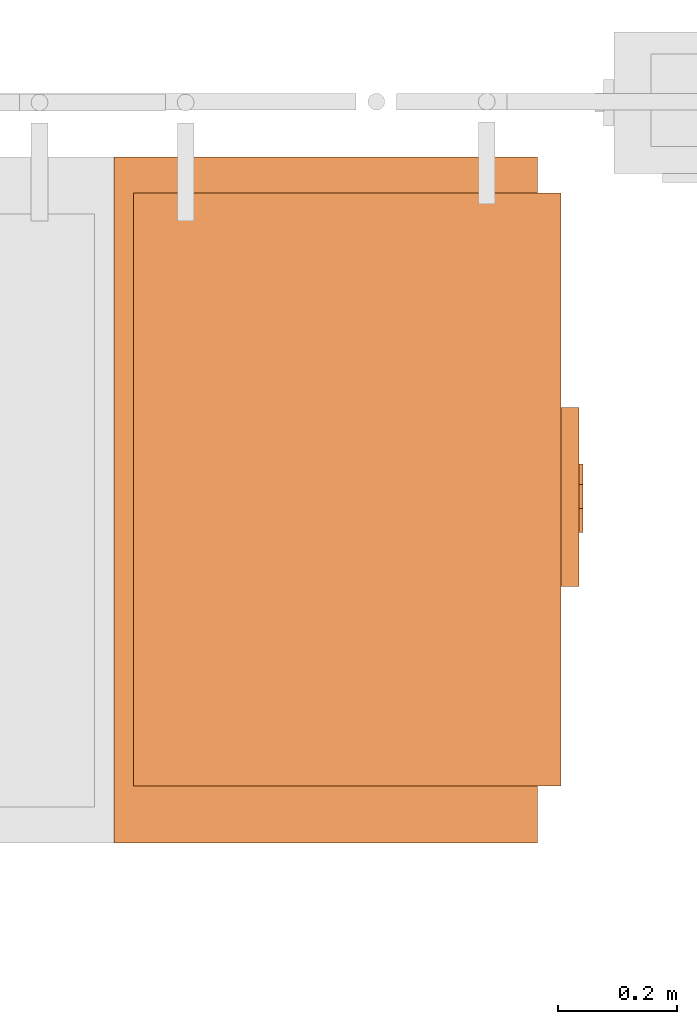
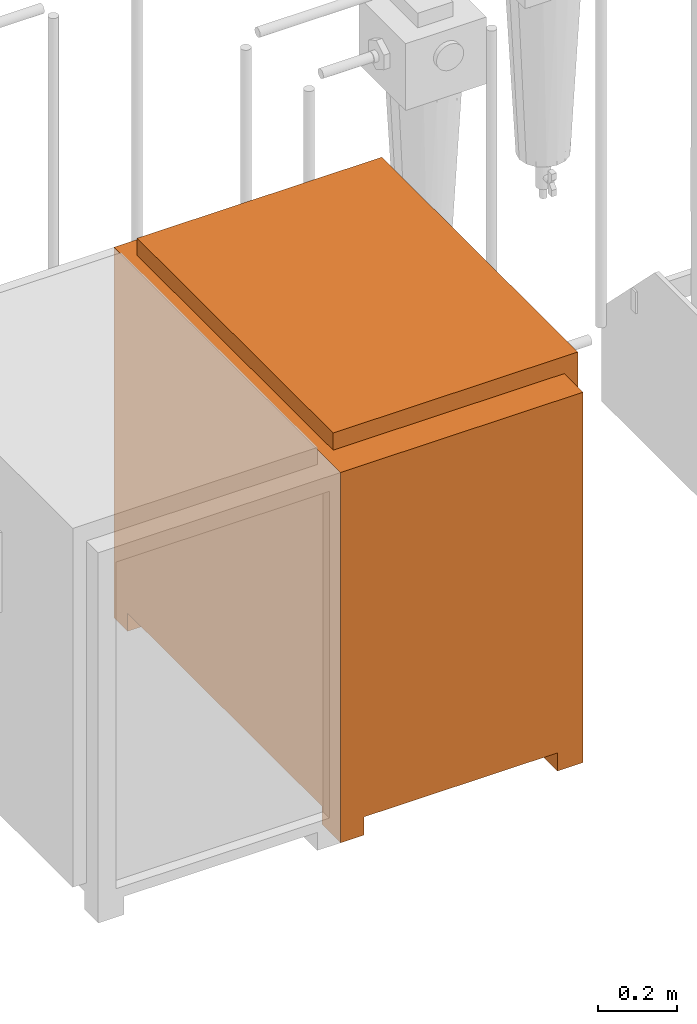
# One storey, part 329 of 331: 1 proxy.
"""IFC2X3 building model written with IfcOpenShell, lengths in millimetres."""

from ifc_helpers import new_model, entity, si_unit, converted_unit, derived_unit, direction, frame, origin, place, context, subcontext, project, spatial, faceted_brep, source, transform, mapped, material, material_list, type_object, type_shapes, element, save


model = new_model("IFC2X3")

# Units and contexts
model_context = context("Model", 3, precision=0.01, world=origin(), true_north=direction((6.12303176911189e-17, 1.0)))
body_context = subcontext(model_context, "Body", "Model", "MODEL_VIEW")
ifc_project = project(units=[si_unit("LENGTHUNIT", "METRE", prefix="MILLI"), si_unit("AREAUNIT", "SQUARE_METRE"), si_unit("VOLUMEUNIT", "CUBIC_METRE"), converted_unit("PLANEANGLEUNIT", "DEGREE", entity("IfcRatioMeasure", 0.0174532925199433), si_unit("PLANEANGLEUNIT", "RADIAN"), dimensions=[0, 0, 0, 0, 0, 0, 0]), si_unit("MASSUNIT", "GRAM", prefix="KILO"), derived_unit("MASSDENSITYUNIT", [(si_unit("MASSUNIT", "GRAM", prefix="KILO"), 1), (si_unit("LENGTHUNIT", "METRE"), -3)]), derived_unit("MOMENTOFINERTIAUNIT", [(si_unit("LENGTHUNIT", "METRE"), 4)]), si_unit("TIMEUNIT", "SECOND"), si_unit("FREQUENCYUNIT", "HERTZ"), si_unit("THERMODYNAMICTEMPERATUREUNIT", "DEGREE_CELSIUS"), derived_unit("THERMALTRANSMITTANCEUNIT", [(si_unit("MASSUNIT", "GRAM", prefix="KILO"), 1), (si_unit("THERMODYNAMICTEMPERATUREUNIT", "KELVIN"), -1), (si_unit("TIMEUNIT", "SECOND"), -3)]), derived_unit("VOLUMETRICFLOWRATEUNIT", [(si_unit("LENGTHUNIT", "METRE"), 3), (si_unit("TIMEUNIT", "SECOND"), -1)]), derived_unit("MASSFLOWRATEUNIT", [(si_unit("MASSUNIT", "GRAM", prefix="KILO"), 1), (si_unit("TIMEUNIT", "SECOND"), -1)]), derived_unit("ROTATIONALFREQUENCYUNIT", [(si_unit("TIMEUNIT", "SECOND"), -1)]), si_unit("ELECTRICCURRENTUNIT", "AMPERE"), si_unit("ELECTRICVOLTAGEUNIT", "VOLT"), si_unit("POWERUNIT", "WATT"), si_unit("FORCEUNIT", "NEWTON", prefix="KILO"), si_unit("ILLUMINANCEUNIT", "LUX"), si_unit("LUMINOUSFLUXUNIT", "LUMEN"), si_unit("LUMINOUSINTENSITYUNIT", "CANDELA"), derived_unit("USERDEFINED", [(si_unit("MASSUNIT", "GRAM", prefix="KILO"), -1), (si_unit("LENGTHUNIT", "METRE"), -2), (si_unit("TIMEUNIT", "SECOND"), 3), (si_unit("LUMINOUSFLUXUNIT", "LUMEN"), 1)]), derived_unit("LINEARVELOCITYUNIT", [(si_unit("LENGTHUNIT", "METRE"), 1), (si_unit("TIMEUNIT", "SECOND"), -1)]), si_unit("PRESSUREUNIT", "PASCAL"), derived_unit("USERDEFINED", [(si_unit("LENGTHUNIT", "METRE"), -2), (si_unit("MASSUNIT", "GRAM", prefix="KILO"), 1), (si_unit("TIMEUNIT", "SECOND"), -2)]), derived_unit("LINEARFORCEUNIT", [(si_unit("MASSUNIT", "GRAM", prefix="KILO"), 1), (si_unit("LENGTHUNIT", "METRE"), 1), (si_unit("TIMEUNIT", "SECOND"), -2), (si_unit("LENGTHUNIT", "METRE"), -1)]), derived_unit("PLANARFORCEUNIT", [(si_unit("MASSUNIT", "GRAM", prefix="KILO"), 1), (si_unit("LENGTHUNIT", "METRE"), 1), (si_unit("TIMEUNIT", "SECOND"), -2), (si_unit("LENGTHUNIT", "METRE"), -2)])], contexts=[model_context])

# Site, building, storey
site_placement = place(None, frame((0.0, -0.00077364408347762, 0.0)))
site = spatial("IfcSite", under=ifc_project, at=site_placement, CompositionType="ELEMENT")
building_placement = place(site_placement, origin())
building = spatial("IfcBuilding", under=site, at=building_placement, CompositionType="ELEMENT")
storey_placement = place(building_placement, origin())
storey = spatial("IfcBuildingStorey", under=building, at=storey_placement, CompositionType="ELEMENT", Elevation=0.0)

# Proxy
ifc_material_1 = material()
ifc_material_2 = material()
ifc_material_3 = material()
ifc_material_list = material_list([ifc_material_1, ifc_material_2, ifc_material_3])
building_element_proxy_type = type_object("IfcBuildingElementProxyType", Name="DC50:DC50", PredefinedType="NOTDEFINED", material=ifc_material_1)
shared_shape = source(origin(), body_context, "Body", "Brep", [
    faceted_brep([(-483.897349584665, 149.270597872865, 819.451035293873), (-483.897349584665, 145.128462249134, 822.629407745831), (-483.897349584665, 141.950089797176, 826.771543369562), (-483.897349584665, 139.952081347083, 831.595162467512), (-483.897349584665, 139.270597872864, 836.771543369562), (-483.897349584665, 139.952081347083, 841.947924271613), (-483.897349584665, 141.950089797176, 846.771543369562), (-483.897349584665, 145.128462249133, 850.913678993293), (-483.897349584665, 149.270597872864, 854.092051445251), (-483.897349584665, 154.094216970814, 856.090059895344), (-483.897349584665, 159.270597872864, 856.771543369562), (-483.897349584665, 164.446978774915, 856.090059895344), (-483.897349584665, 169.270597872864, 854.092051445251), (-483.897349584665, 173.412733496595, 850.913678993293), (-483.897349584665, 176.591105948553, 846.771543369562), (-483.897349584665, 178.589114398646, 841.947924271613), (-483.897349584665, 179.270597872864, 836.771543369562), (-483.897349584665, 178.589114398646, 831.595162467512), (-483.897349584665, 176.591105948553, 826.771543369562), (-483.897349584665, 173.412733496595, 822.629407745831), (-483.897349584665, 169.270597872865, 819.451035293873), (-483.897349584665, 164.446978774915, 817.453026843781), (-483.897349584665, 159.270597872865, 816.771543369562), (-483.897349584665, 154.094216970814, 817.453026843781), (-477.5, 164.446978774915, 856.090059895344), (-477.5, 159.270597872864, 856.771543369562), (-477.5, 154.094216970814, 856.090059895344), (-477.5, 149.270597872864, 854.092051445251), (-477.5, 145.128462249133, 850.913678993293), (-477.5, 141.950089797176, 846.771543369562), (-477.5, 139.952081347083, 841.947924271613), (-477.5, 139.270597872864, 836.771543369562), (-477.5, 139.952081347083, 831.595162467512), (-477.5, 141.950089797176, 826.771543369562), (-477.5, 145.128462249134, 822.629407745831), (-477.5, 149.270597872865, 819.451035293873), (-477.5, 154.094216970814, 817.453026843781), (-477.5, 159.270597872865, 816.771543369562), (-477.5, 164.446978774915, 817.453026843781), (-477.5, 169.270597872865, 819.451035293873), (-477.5, 173.412733496595, 822.629407745831), (-477.5, 176.591105948553, 826.771543369562), (-477.5, 178.589114398646, 831.595162467512), (-477.5, 179.270597872864, 836.771543369562), (-477.5, 178.589114398646, 841.947924271613), (-477.5, 176.591105948553, 846.771543369562), (-477.5, 173.412733496595, 850.913678993293), (-477.5, 169.270597872864, 854.092051445251)], [[[0, 1, 2, 3, 4, 5, 6, 7, 8, 9, 10, 11, 12, 13, 14, 15, 16, 17, 18, 19, 20, 21, 22, 23]], [[24, 25, 26, 27, 28, 29, 30, 31, 32, 33, 34, 35, 36, 37, 38, 39, 40, 41, 42, 43, 44, 45, 46, 47]], [[42, 17, 16, 43]], [[41, 18, 17, 42]], [[20, 19, 40, 39]], [[41, 40, 19, 18]], [[21, 20, 39, 38]], [[22, 21, 38, 37]], [[36, 23, 22, 37]], [[35, 0, 23, 36]], [[2, 1, 34, 33]], [[35, 34, 1, 0]], [[3, 2, 33, 32]], [[4, 3, 32, 31]], [[30, 5, 4, 31]], [[29, 6, 5, 30]], [[8, 7, 28, 27]], [[29, 28, 7, 6]], [[9, 8, 27, 26]], [[10, 9, 26, 25]], [[24, 11, 10, 25]], [[47, 12, 11, 24]], [[14, 13, 46, 45]], [[47, 46, 13, 12]], [[15, 14, 45, 44]], [[16, 15, 44, 43]]]),
    faceted_brep([(-483.897349584665, 224.270597872864, 819.451035293874), (-483.897349584665, 220.128462249133, 822.629407745831), (-483.897349584665, 216.950089797176, 826.771543369562), (-483.897349584665, 214.952081347083, 831.595162467512), (-483.897349584665, 214.270597872864, 836.771543369563), (-483.897349584665, 214.952081347083, 841.947924271613), (-483.897349584665, 216.950089797176, 846.771543369563), (-483.897349584665, 220.128462249133, 850.913678993294), (-483.897349584665, 224.270597872864, 854.092051445251), (-483.897349584665, 229.094216970814, 856.090059895344), (-483.897349584665, 234.270597872864, 856.771543369563), (-483.897349584665, 239.446978774915, 856.090059895344), (-483.897349584665, 244.270597872864, 854.092051445251), (-483.897349584665, 248.412733496595, 850.913678993294), (-483.897349584665, 251.591105948553, 846.771543369563), (-483.897349584665, 253.589114398646, 841.947924271613), (-483.897349584665, 254.270597872864, 836.771543369563), (-483.897349584665, 253.589114398646, 831.595162467512), (-483.897349584665, 251.591105948553, 826.771543369563), (-483.897349584665, 248.412733496595, 822.629407745832), (-483.897349584665, 244.270597872864, 819.451035293874), (-483.897349584665, 239.446978774915, 817.453026843781), (-483.897349584665, 234.270597872864, 816.771543369562), (-483.897349584665, 229.094216970814, 817.453026843781), (-477.5, 239.446978774915, 856.090059895344), (-477.5, 234.270597872864, 856.771543369563), (-477.5, 229.094216970814, 856.090059895344), (-477.5, 224.270597872864, 854.092051445251), (-477.5, 220.128462249133, 850.913678993294), (-477.5, 216.950089797176, 846.771543369563), (-477.5, 214.952081347083, 841.947924271613), (-477.5, 214.270597872864, 836.771543369562), (-477.5, 214.952081347083, 831.595162467512), (-477.5, 216.950089797176, 826.771543369562), (-477.5, 220.128462249133, 822.629407745831), (-477.5, 224.270597872864, 819.451035293874), (-477.5, 229.094216970814, 817.453026843781), (-477.5, 234.270597872864, 816.771543369562), (-477.5, 239.446978774915, 817.453026843781), (-477.5, 244.270597872864, 819.451035293874), (-477.5, 248.412733496595, 822.629407745832), (-477.5, 251.591105948553, 826.771543369563), (-477.5, 253.589114398646, 831.595162467512), (-477.5, 254.270597872864, 836.771543369563), (-477.5, 253.589114398646, 841.947924271613), (-477.5, 251.591105948553, 846.771543369563), (-477.5, 248.412733496595, 850.913678993294), (-477.5, 244.270597872864, 854.092051445251)], [[[0, 1, 2, 3, 4, 5, 6, 7, 8, 9, 10, 11, 12, 13, 14, 15, 16, 17, 18, 19, 20, 21, 22, 23]], [[24, 25, 26, 27, 28, 29, 30, 31, 32, 33, 34, 35, 36, 37, 38, 39, 40, 41, 42, 43, 44, 45, 46, 47]], [[42, 17, 16, 43]], [[41, 18, 17, 42]], [[20, 19, 40, 39]], [[41, 40, 19, 18]], [[21, 20, 39, 38]], [[22, 21, 38, 37]], [[36, 23, 22, 37]], [[35, 0, 23, 36]], [[2, 1, 34, 33]], [[35, 34, 1, 0]], [[3, 2, 33, 32]], [[4, 3, 32, 31]], [[30, 5, 4, 31]], [[29, 6, 5, 30]], [[8, 7, 28, 27]], [[29, 28, 7, 6]], [[9, 8, 27, 26]], [[10, 9, 26, 25]], [[24, 11, 10, 25]], [[47, 12, 11, 24]], [[14, 13, 46, 45]], [[47, 46, 13, 12]], [[15, 14, 45, 44]], [[16, 15, 44, 43]]]),
    faceted_brep([(-483.897349584665, 184.252601976697, 870.671734278311), (-483.897349584665, 180.110466352966, 873.850106730268), (-483.897349584665, 176.932093901008, 877.992242353999), (-483.897349584665, 174.934085450915, 882.815861451949), (-483.897349584665, 174.252601976696, 887.992242353999), (-483.897349584665, 174.934085450915, 893.16862325605), (-483.897349584665, 176.932093901008, 897.992242353999), (-483.897349584665, 180.110466352965, 902.13437797773), (-483.897349584665, 184.252601976696, 905.312750429688), (-483.897349584665, 189.076221074646, 907.310758879781), (-483.897349584665, 194.252601976696, 907.992242353999), (-483.897349584665, 199.428982878747, 907.310758879781), (-483.897349584665, 204.252601976696, 905.312750429688), (-483.897349584665, 208.394737600427, 902.13437797773), (-483.897349584665, 211.573110052385, 897.992242353999), (-483.897349584665, 213.571118502478, 893.16862325605), (-483.897349584665, 214.252601976696, 887.992242353999), (-483.897349584665, 213.571118502478, 882.815861451949), (-483.897349584665, 211.573110052385, 877.992242354), (-483.897349584665, 208.394737600427, 873.850106730269), (-483.897349584665, 204.252601976697, 870.671734278311), (-483.897349584665, 199.428982878747, 868.673725828218), (-483.897349584665, 194.252601976697, 867.992242353999), (-483.897349584665, 189.076221074646, 868.673725828218), (-477.5, 199.428982878747, 907.310758879781), (-477.5, 194.252601976696, 907.992242353999), (-477.5, 189.076221074646, 907.310758879781), (-477.5, 184.252601976696, 905.312750429688), (-477.5, 180.110466352965, 902.13437797773), (-477.5, 176.932093901008, 897.992242353999), (-477.5, 174.934085450915, 893.16862325605), (-477.5, 174.252601976696, 887.992242353999), (-477.5, 174.934085450915, 882.815861451949), (-477.5, 176.932093901008, 877.992242353999), (-477.5, 180.110466352966, 873.850106730268), (-477.5, 184.252601976697, 870.671734278311), (-477.5, 189.076221074646, 868.673725828218), (-477.5, 194.252601976697, 867.992242353999), (-477.5, 199.428982878747, 868.673725828218), (-477.5, 204.252601976697, 870.671734278311), (-477.5, 208.394737600427, 873.850106730269), (-477.5, 211.573110052385, 877.992242354), (-477.5, 213.571118502478, 882.815861451949), (-477.5, 214.252601976696, 887.992242353999), (-477.5, 213.571118502478, 893.16862325605), (-477.5, 211.573110052385, 897.992242353999), (-477.5, 208.394737600427, 902.13437797773), (-477.5, 204.252601976696, 905.312750429688)], [[[0, 1, 2, 3, 4, 5, 6, 7, 8, 9, 10, 11, 12, 13, 14, 15, 16, 17, 18, 19, 20, 21, 22, 23]], [[24, 25, 26, 27, 28, 29, 30, 31, 32, 33, 34, 35, 36, 37, 38, 39, 40, 41, 42, 43, 44, 45, 46, 47]], [[42, 17, 16, 43]], [[41, 18, 17, 42]], [[20, 19, 40, 39]], [[41, 40, 19, 18]], [[21, 20, 39, 38]], [[22, 21, 38, 37]], [[36, 23, 22, 37]], [[35, 0, 23, 36]], [[2, 1, 34, 33]], [[35, 34, 1, 0]], [[3, 2, 33, 32]], [[4, 3, 32, 31]], [[30, 5, 4, 31]], [[29, 6, 5, 30]], [[8, 7, 28, 27]], [[29, 28, 7, 6]], [[9, 8, 27, 26]], [[10, 9, 26, 25]], [[24, 11, 10, 25]], [[47, 12, 11, 24]], [[14, 13, 46, 45]], [[47, 46, 13, 12]], [[15, 14, 45, 44]], [[16, 15, 44, 43]]]),
    faceted_brep([(-477.500000000001, 300.0, 670.684385919393), (-477.500000000002, 88.5891967833818, 670.684385919393), (-447.500000000001, 88.5891967833817, 670.684385919393), (-447.500000000001, 300.0, 670.684385919393), (-477.500000000001, 300.0, 527.078251788917), (-447.500000000001, 300.0, 527.078251788917), (-447.500000000001, 88.5891967833817, 527.078251788917), (-477.500000000002, 88.5891967833818, 527.078251788917)], [[[0, 1, 2, 3]], [[4, 5, 6, 7]], [[1, 0, 4, 7]], [[2, 1, 7, 6]], [[3, 2, 6, 5]], [[0, 3, 5, 4]]]),
    faceted_brep([(-407.500000000004, 680.0, 1146.89219153294), (302.832876680296, 680.0, 1146.89219153294), (302.832876680296, 775.106496329684, 1146.89219153294), (-407.500000000003, 775.106496329686, 1146.89219153294), (302.832876680296, 775.106496329684, 0.0), (302.832876680296, 680.0, 0.0), (234.287667008801, 680.0, 0.0), (234.287667008801, 775.106496329684, 0.0), (-407.500000000004, 680.0, 0.0), (-332.499999999999, 680.0, 0.0), (-332.499999999999, 680.0, 56.089418150774), (234.287667008801, 680.0, 56.089418150774), (234.287667008802, 775.106496329684, 56.089418150774), (-332.499999999999, 775.106496329686, 56.089418150774), (-332.499999999999, 775.106496329686, 0.0), (-407.500000000003, 775.106496329686, 0.0)], [[[0, 1, 2, 3]], [[4, 5, 6, 7]], [[1, 0, 8, 9, 10, 11, 6, 5]], [[2, 1, 5, 4]], [[3, 2, 4, 7, 12, 13, 14, 15]], [[0, 3, 15, 8]], [[13, 10, 9, 14]], [[11, 12, 7, 6]], [[12, 11, 10, 13]], [[8, 15, 14, 9]]]),
    faceted_brep([(-477.500000000001, 345.0, 970.0), (-477.500000000002, 45.0, 970.0), (-447.500000000001, 45.0, 970.0), (-447.500000000001, 345.0, 970.0), (-477.500000000001, 345.0, 722.191638385122), (-447.500000000001, 345.0, 722.191638385122), (-447.500000000001, 45.0, 722.191638385122), (-477.500000000002, 45.0, 722.191638385122), (-477.500000000001, 300.0, 920.0), (-477.500000000002, 88.5891967833821, 920.0), (-477.500000000002, 88.589196783382, 805.330017864731), (-477.500000000001, 300.0, 805.330017864731), (-467.5, 88.589196783382, 920.0), (-467.5, 300.0, 920.0), (-467.5, 300.0, 805.330017864731), (-467.5, 88.589196783382, 805.330017864731)], [[[0, 1, 2, 3]], [[4, 5, 6, 7]], [[1, 0, 4, 7], [8, 9, 10, 11]], [[2, 1, 7, 6]], [[3, 2, 6, 5]], [[0, 3, 5, 4]], [[12, 13, 14, 15]], [[13, 12, 9, 8]], [[14, 13, 8, 11]], [[15, 14, 11, 10]], [[12, 15, 10, 9]]]),
    faceted_brep([(-407.500000000001, -375.0, 1146.89219153294), (302.832876680294, -375.0, 1146.89219153294), (302.832876680296, 680.0, 1146.89219153294), (-407.5, 680.0, 1146.89219153294), (302.832876680295, -305.288454892349, 0.0), (302.832876680294, -375.0, 0.0), (234.2876670088, -375.0, 0.0), (234.2876670088, -305.288454892349, 0.0), (-407.500000000001, -375.0, 0.0), (-332.500000000001, -375.0, 0.0), (-332.500000000001, -375.0, 56.089418150774), (234.2876670088, -375.0, 56.089418150774), (-355.365527080025, -375.0, 1100.0), (269.430307946747, -375.0, 1100.0), (269.430307946745, -375.0, 88.1437175093121), (-355.365527080026, -375.0, 88.1437175093141), (302.832876680295, -305.288454892349, 56.089418150774), (302.832876680296, 680.0, 56.089418150774), (-407.5, 680.0, 56.089418150774), (-407.500000000001, -305.288454892346, 56.089418150774), (-407.500000000001, -305.288454892346, 0.0), (269.430307946747, -342.939909824343, 1100.0), (-355.365527080025, -342.939909824343, 1100.0), (-355.365527080026, -342.939909824343, 88.1437175093141), (269.430307946745, -342.939909824343, 88.1437175093121), (234.2876670088, -305.288454892349, 56.089418150774), (-332.500000000001, -305.288454892347, 56.089418150774), (-332.500000000001, -305.288454892347, 0.0)], [[[0, 1, 2, 3]], [[4, 5, 6, 7]], [[1, 0, 8, 9, 10, 11, 6, 5], [12, 13, 14, 15]], [[2, 1, 5, 4, 16, 17]], [[3, 2, 17, 18]], [[0, 3, 18, 19, 20, 8]], [[21, 22, 23, 24]], [[22, 21, 13, 12]], [[23, 22, 12, 15]], [[24, 23, 15, 14]], [[21, 24, 14, 13]], [[17, 16, 25, 11, 10, 26, 19, 18]], [[20, 19, 26, 27]], [[26, 10, 9, 27]], [[11, 25, 7, 6]], [[16, 4, 7, 25]], [[8, 20, 27, 9]]]),
    faceted_brep([(269.43030794675, 680.0, 1199.899117756), (-447.5, 680.0, 1199.899117756), (-447.500000000001, -315.0, 1199.899117756), (269.430307946746, -315.0, 1199.899117756), (269.43030794675, 680.0, 88.1437175093128), (269.430307946746, -315.0, 88.1437175093128), (-447.500000000001, -315.0, 88.1437175093128), (-447.499999999999, 680.0, 88.1437175093128)], [[[0, 1, 2, 3]], [[4, 5, 6, 7]], [[1, 0, 4, 7]], [[2, 1, 7, 6]], [[3, 2, 6, 5]], [[0, 3, 5, 4]]]),
])
type_shapes(building_element_proxy_type, [shared_shape])
proxy_placement = place(storey_placement, frame((52682.5036168841, -1154.89360536885, -700.0), z_axis=(0.0, 0.0, 1.0), x_axis=(-1.0, 0.0, 0.0)))
element("IfcBuildingElementProxy", 1, at=proxy_placement, inside=storey, type_object=building_element_proxy_type, material=ifc_material_list, Name="DC50:DC50", ObjectType="DC50:DC50", context=body_context, shape_type="MappedRepresentation", body=[
    mapped(shared_shape, transform((0.0, 0.0, 0.0), scale=1.0)),
])

save(model, "model.ifc")
